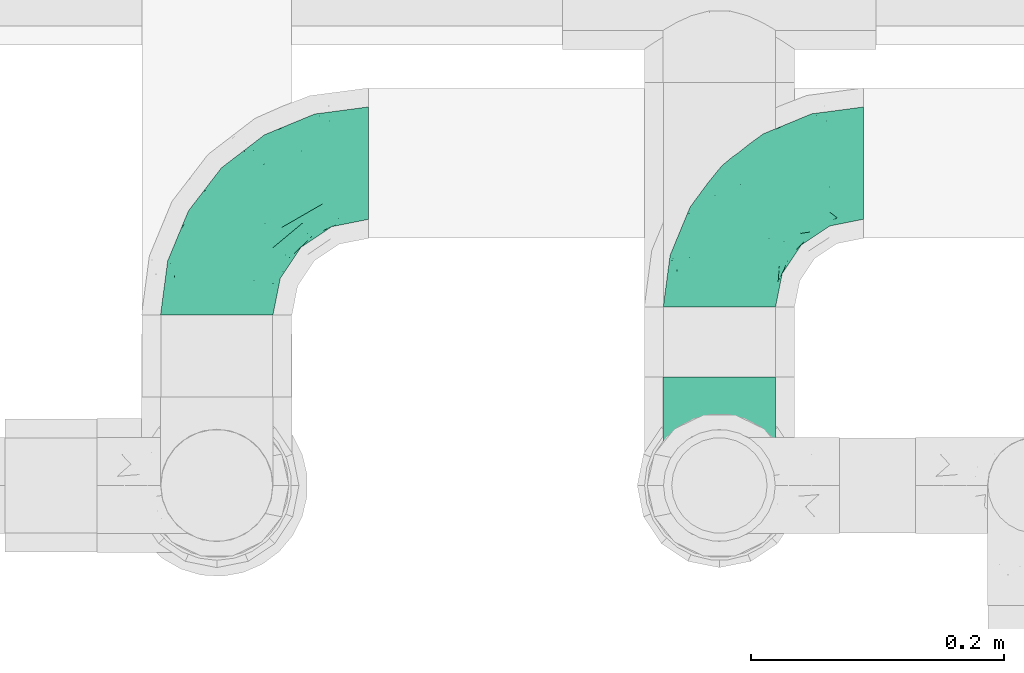
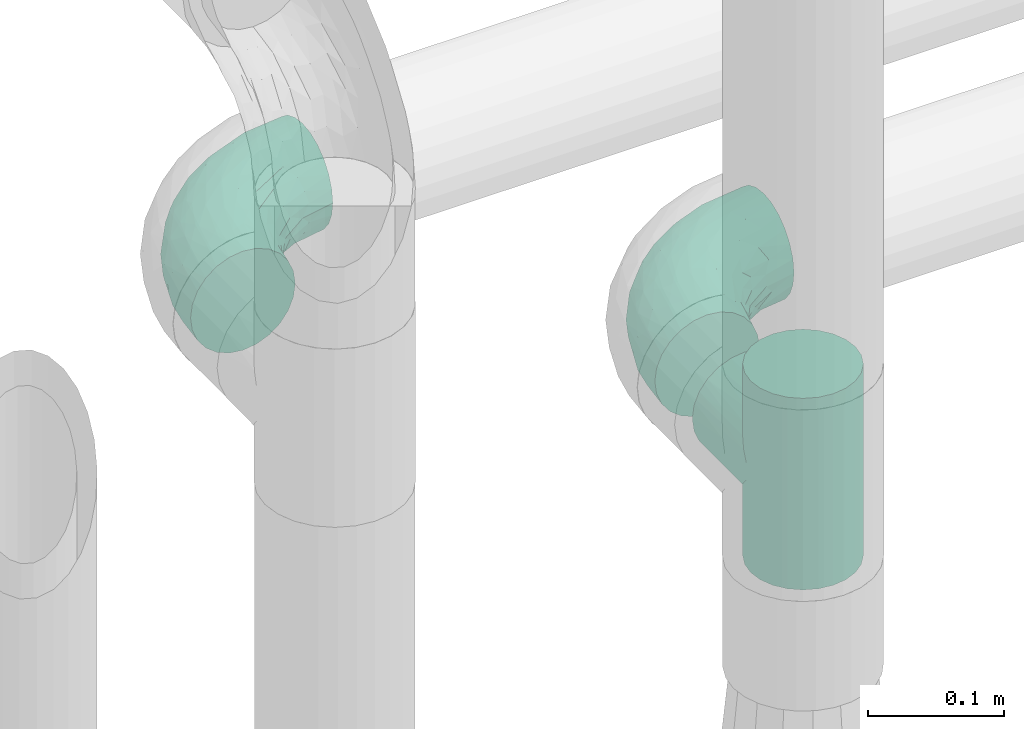
# One storey, part 705 of 824: 3 flow fittings.
"""IFC2X3 building model written with IfcOpenShell, lengths in millimetres."""

from ifc_helpers import new_model, entity, si_unit, converted_unit, derived_unit, direction, frame, origin, place, context, subcontext, project, spatial, faceted_brep, source, transform, mapped, material, type_object, type_shapes, element, save


model = new_model("IFC2X3")

# Units and contexts
model_context = context("Model", 3, precision=0.01, world=origin(), true_north=direction((6.12303176911189e-17, 1.0)))
body_context = subcontext(model_context, "Body", "Model", "MODEL_VIEW")
ifc_project = project(units=[si_unit("LENGTHUNIT", "METRE", prefix="MILLI"), si_unit("AREAUNIT", "SQUARE_METRE"), si_unit("VOLUMEUNIT", "CUBIC_METRE"), converted_unit("PLANEANGLEUNIT", "DEGREE", entity("IfcRatioMeasure", 0.0174532925199433), si_unit("PLANEANGLEUNIT", "RADIAN"), dimensions=[0, 0, 0, 0, 0, 0, 0]), si_unit("MASSUNIT", "GRAM", prefix="KILO"), derived_unit("MASSDENSITYUNIT", [(si_unit("MASSUNIT", "GRAM", prefix="KILO"), 1), (si_unit("LENGTHUNIT", "METRE"), -3)]), derived_unit("MOMENTOFINERTIAUNIT", [(si_unit("LENGTHUNIT", "METRE"), 4)]), si_unit("TIMEUNIT", "SECOND"), si_unit("FREQUENCYUNIT", "HERTZ"), si_unit("THERMODYNAMICTEMPERATUREUNIT", "DEGREE_CELSIUS"), derived_unit("THERMALTRANSMITTANCEUNIT", [(si_unit("MASSUNIT", "GRAM", prefix="KILO"), 1), (si_unit("THERMODYNAMICTEMPERATUREUNIT", "KELVIN"), -1), (si_unit("TIMEUNIT", "SECOND"), -3)]), derived_unit("VOLUMETRICFLOWRATEUNIT", [(si_unit("LENGTHUNIT", "METRE"), 3), (si_unit("TIMEUNIT", "SECOND"), -1)]), derived_unit("MASSFLOWRATEUNIT", [(si_unit("MASSUNIT", "GRAM", prefix="KILO"), 1), (si_unit("TIMEUNIT", "SECOND"), -1)]), derived_unit("ROTATIONALFREQUENCYUNIT", [(si_unit("TIMEUNIT", "SECOND"), -1)]), si_unit("ELECTRICCURRENTUNIT", "AMPERE"), si_unit("ELECTRICVOLTAGEUNIT", "VOLT"), si_unit("POWERUNIT", "WATT"), si_unit("FORCEUNIT", "NEWTON", prefix="KILO"), si_unit("ILLUMINANCEUNIT", "LUX"), si_unit("LUMINOUSFLUXUNIT", "LUMEN"), si_unit("LUMINOUSINTENSITYUNIT", "CANDELA"), derived_unit("USERDEFINED", [(si_unit("MASSUNIT", "GRAM", prefix="KILO"), -1), (si_unit("LENGTHUNIT", "METRE"), -2), (si_unit("TIMEUNIT", "SECOND"), 3), (si_unit("LUMINOUSFLUXUNIT", "LUMEN"), 1)]), derived_unit("LINEARVELOCITYUNIT", [(si_unit("LENGTHUNIT", "METRE"), 1), (si_unit("TIMEUNIT", "SECOND"), -1)]), si_unit("PRESSUREUNIT", "PASCAL"), derived_unit("USERDEFINED", [(si_unit("LENGTHUNIT", "METRE"), -2), (si_unit("MASSUNIT", "GRAM", prefix="KILO"), 1), (si_unit("TIMEUNIT", "SECOND"), -2)]), derived_unit("LINEARFORCEUNIT", [(si_unit("MASSUNIT", "GRAM", prefix="KILO"), 1), (si_unit("LENGTHUNIT", "METRE"), 1), (si_unit("TIMEUNIT", "SECOND"), -2), (si_unit("LENGTHUNIT", "METRE"), -1)]), derived_unit("PLANARFORCEUNIT", [(si_unit("MASSUNIT", "GRAM", prefix="KILO"), 1), (si_unit("LENGTHUNIT", "METRE"), 1), (si_unit("TIMEUNIT", "SECOND"), -2), (si_unit("LENGTHUNIT", "METRE"), -2)])], contexts=[model_context])

# Site, building, storey
site_placement = place(None, origin())
site = spatial("IfcSite", under=ifc_project, at=site_placement, CompositionType="ELEMENT")
building_placement = place(site_placement, origin())
building = spatial("IfcBuilding", under=site, at=building_placement, CompositionType="ELEMENT")
storey_placement = place(building_placement, frame((0.0, 0.0, 28200.0)))
storey = spatial("IfcBuildingStorey", under=building, at=storey_placement, CompositionType="ELEMENT", Elevation=28200.0)

# Flow fittings
ifc_material = material()
pipe_fitting_type_1 = type_object("IfcPipeFittingType", PredefinedType="NOTDEFINED", material=ifc_material)
shared_shape_1 = source(origin(), body_context, "Body", "Brep", [
    faceted_brep([(-120.0, 22.25, -38.54), (-120.0, 11.52, -42.98), (-120.0, 0.0, -44.5), (-120.0, -11.52, -42.98), (-120.0, -22.25, -38.54), (-120.0, -31.47, -31.47), (-120.0, -38.54, -22.25), (-120.0, -42.98, -11.52), (-120.0, -44.5, 0.0), (-120.0, -42.98, 11.52), (-120.0, -38.54, 22.25), (-120.0, -31.47, 31.47), (-120.0, -22.25, 38.54), (-120.0, -11.52, 42.98), (-120.0, 0.0, 44.5), (-120.0, 11.52, 42.98), (-120.0, 22.25, 38.54), (-120.0, 31.47, 31.47), (-120.0, 38.54, 22.25), (-120.0, 42.98, 11.52), (-120.0, 44.5, 0.0), (-120.0, 42.98, -11.52), (-120.0, 38.54, -22.25), (-120.0, 31.47, -31.47), (0.0, 120.0, -44.5), (-11.52, 120.0, -42.98), (-22.25, 120.0, -38.54), (-31.47, 120.0, -31.47), (-38.54, 120.0, -22.25), (-42.98, 120.0, -11.52), (-44.5, 120.0, 0.0), (-42.98, 120.0, 11.52), (-38.54, 120.0, 22.25), (-31.47, 120.0, 31.47), (-22.25, 120.0, 38.54), (-11.52, 120.0, 42.98), (0.0, 120.0, 44.5), (11.52, 120.0, 42.98), (22.25, 120.0, 38.54), (31.47, 120.0, 31.47), (38.54, 120.0, 22.25), (42.98, 120.0, 11.52), (44.5, 120.0, 0.0), (42.98, 120.0, -11.52), (38.54, 120.0, -22.25), (31.47, 120.0, -31.47), (22.25, 120.0, -38.54), (11.52, 120.0, -42.98), (-20.51, 85.66, 41.98), (-29.31, 93.55, 36.45), (-98.0, -41.6, 0.0), (-80.92, -37.22, 14.68), (-66.68, -9.63, 39.67), (-84.59, -24.55, 33.9), (-50.35, -12.87, 32.85), (-77.42, -38.89, 0.0), (-22.01, -9.62, 13.21), (-37.75, -22.46, 0.0), (-20.72, -9.39, 0.0), (-89.18, -33.47, 25.4), (12.87, 50.35, 32.85), (24.55, 84.59, 33.9), (9.63, 66.68, 39.67), (-49.55, -27.06, 11.21), (-28.67, -9.99, 21.67), (-52.01, -22.41, 23.47), (-95.53, -16.28, 40.49), (-86.01, -3.42, 43.77), (22.41, 52.01, 23.47), (9.05, 21.37, 13.44), (26.5, 49.37, 12.73), (33.47, 89.18, 25.4), (37.22, 80.92, 14.68), (16.28, 95.53, 40.49), (3.42, 86.01, 43.77), (-7.84, 52.6, 43.16), (-84.39, 31.88, 36.84), (-30.52, 34.28, 44.33), (-21.99, 28.55, 42.22), (-93.56, 38.23, 28.63), (-65.04, 31.74, 41.51), (-91.98, 19.0, 41.83), (-34.03, 70.24, 39.41), (-96.36, 44.0, 18.64), (-98.49, 46.74, 8.65), (-76.5, 56.97, 9.76), (-4.96, 4.47, 11.32), (-7.16, 6.18, 18.93), (-56.62, 75.93, 12.18), (-66.61, 66.61, 0.0), (-92.12, 7.25, 44.33), (-7.23, 92.66, 44.32), (30.68, 57.59, 0.0), (-44.45, 94.8, 18.75), (-36.39, 101.98, 28.14), (-46.83, 97.45, 9.69), (-38.03, 47.61, 43.21), (-24.7, 65.7, 43.29), (41.6, 98.0, 0.0), (-54.11, 72.8, 21.53), (-47.95, 9.75, 42.93), (-18.65, 18.65, 37.89), (-91.11, 50.25, 0.0), (-50.25, 91.11, 0.0), (-57.59, -30.68, 0.0), (-44.16, 67.2, 34.92), (-55.15, 62.16, 29.74), (-68.1, 47.21, 32.31), (-51.09, 51.09, 38.36), (-16.69, 62.62, 44.46), (-58.26, 18.84, 44.48), (-71.55, 55.71, 20.49), (-43.13, 80.04, 29.45), (-37.23, 0.88, 36.78), (-18.15, 10.22, 33.09), (5.51, 28.08, 26.74), (-3.68, 3.68, 0.0), (9.39, 20.72, 0.0), (-2.58, 27.98, 33.59), (-2.38, 41.22, 38.93), (-16.09, 4.55, 27.06), (38.89, 77.42, 0.0), (22.46, 37.75, 0.0), (-92.66, 7.23, -44.32), (-22.01, -9.62, -13.21), (-49.81, -26.66, -12.91), (-28.67, -9.99, -21.67), (-62.62, 16.69, -44.46), (-65.04, 31.74, -41.51), (-38.89, 47.26, -43.11), (-56.62, 75.93, -12.18), (-93.56, 38.23, -28.63), (-84.39, 31.88, -36.84), (16.28, 95.53, -40.49), (3.42, 86.01, -43.77), (-98.49, 46.74, -8.65), (-44.45, 94.8, -18.75), (-54.11, 72.8, -21.53), (-76.5, 56.97, -9.76), (24.55, 84.59, -33.9), (9.63, 66.68, -39.67), (-96.36, 44.0, -18.64), (-29.4, 93.16, -36.47), (-91.98, 19.0, -41.83), (-80.92, -37.22, -14.68), (-52.6, 7.84, -43.16), (-86.01, -3.42, -43.77), (-89.18, -33.47, -25.4), (-52.01, -22.41, -23.47), (-50.35, -12.87, -32.85), (-84.59, -24.55, -33.9), (-66.68, -9.63, -39.67), (-95.53, -16.28, -40.49), (-68.1, 47.21, -32.31), (-35.81, 11.1, -40.85), (-19.61, 28.53, -41.59), (-18.65, 18.65, -37.89), (-4.97, 4.47, -11.34), (9.05, 21.37, -13.44), (-34.28, 30.52, -44.33), (-9.75, 47.95, -42.93), (-2.58, 27.98, -33.59), (-18.15, 10.22, -33.09), (-46.83, 97.45, -9.69), (12.87, 50.35, -32.85), (26.8, 49.13, -11.4), (-7.34, 92.03, -44.33), (-21.02, 83.86, -42.03), (-44.6, 66.82, -34.8), (-55.46, 62.18, -29.47), (37.22, 80.92, -14.68), (33.47, 89.18, -25.4), (-34.39, 70.11, -39.28), (-25.04, 64.41, -43.37), (-18.84, 58.26, -44.48), (22.41, 52.01, -23.47), (-36.39, 101.98, -28.14), (-51.09, 51.09, -38.36), (-43.13, 80.04, -29.45), (-71.55, 55.71, -20.49), (-7.15, 6.2, -18.94), (5.51, 28.08, -26.74), (-37.23, 0.88, -36.78), (-2.38, 41.22, -38.93), (-16.09, 4.55, -27.06)], [[[0, 1, 2, 3, 4, 5, 6, 7, 8, 9, 10, 11, 12, 13, 14, 15, 16, 17, 18, 19, 20, 21, 22, 23]], [[24, 25, 26, 27, 28, 29, 30, 31, 32, 33, 34, 35, 36, 37, 38, 39, 40, 41, 42, 43, 44, 45, 46, 47]], [[48, 34, 49]], [[50, 51, 9]], [[52, 53, 54]], [[9, 51, 10]], [[55, 51, 50]], [[56, 57, 58]], [[51, 59, 10]], [[60, 61, 62]], [[63, 64, 65]], [[13, 12, 66]], [[67, 14, 13]], [[68, 69, 70]], [[71, 68, 72]], [[38, 73, 61]], [[74, 75, 62]], [[17, 16, 76]], [[77, 78, 75]], [[79, 18, 17]], [[80, 76, 81]], [[35, 34, 48]], [[49, 82, 48]], [[18, 83, 19]], [[16, 81, 76]], [[20, 19, 84]], [[85, 84, 83]], [[56, 86, 87]], [[85, 88, 89]], [[37, 36, 74]], [[90, 14, 67]], [[79, 17, 76]], [[63, 65, 51]], [[13, 66, 67]], [[61, 39, 38]], [[91, 74, 36]], [[70, 92, 72]], [[93, 94, 32]], [[95, 88, 93]], [[62, 73, 74]], [[82, 96, 97]], [[40, 72, 41]], [[72, 68, 70]], [[71, 72, 40]], [[34, 33, 49]], [[72, 98, 41]], [[99, 93, 88]], [[71, 39, 61]], [[78, 100, 101]], [[85, 89, 102]], [[53, 52, 66]], [[103, 95, 30]], [[12, 11, 53]], [[103, 89, 88]], [[104, 57, 63]], [[91, 48, 97]], [[93, 32, 31]], [[33, 32, 94]], [[16, 15, 81]], [[105, 106, 107]], [[76, 107, 79]], [[35, 91, 36]], [[80, 96, 108]], [[31, 95, 93]], [[65, 53, 59]], [[73, 38, 37]], [[75, 74, 109]], [[61, 60, 68]], [[11, 10, 59]], [[54, 53, 65]], [[100, 67, 52]], [[110, 81, 90]], [[15, 14, 90]], [[76, 80, 108]], [[107, 76, 108]], [[83, 79, 111]], [[94, 49, 33]], [[82, 105, 108]], [[84, 85, 102]], [[111, 88, 85]], [[99, 88, 111]], [[94, 93, 112]], [[48, 91, 35]], [[74, 91, 109]], [[69, 87, 86]], [[113, 54, 114]], [[64, 56, 87]], [[60, 115, 68]], [[116, 117, 86]], [[69, 68, 115]], [[79, 83, 18]], [[85, 83, 111]], [[81, 110, 80]], [[110, 77, 96]], [[110, 96, 80]], [[97, 96, 109]], [[107, 108, 105]], [[111, 79, 107]], [[77, 75, 109]], [[118, 119, 101]], [[96, 77, 109]], [[77, 110, 100]], [[67, 100, 110]], [[100, 52, 113]], [[60, 119, 118]], [[118, 120, 115]], [[64, 54, 65]], [[114, 120, 118]], [[118, 115, 60]], [[115, 120, 87]], [[74, 73, 37]], [[61, 73, 62]], [[53, 66, 12]], [[67, 66, 52]], [[110, 90, 67]], [[15, 90, 81]], [[105, 49, 112]], [[96, 82, 108]], [[119, 60, 62]], [[118, 101, 114]], [[62, 75, 119]], [[78, 119, 75]], [[49, 105, 82]], [[105, 112, 106]], [[99, 112, 93]], [[111, 107, 106]], [[113, 114, 101]], [[54, 120, 114]], [[100, 113, 101]], [[52, 54, 113]], [[20, 84, 102]], [[83, 84, 19]], [[111, 106, 99]], [[112, 99, 106]], [[100, 78, 77]], [[119, 78, 101]], [[39, 71, 40]], [[68, 71, 61]], [[65, 59, 51]], [[11, 59, 53]], [[30, 95, 31]], [[103, 88, 95]], [[9, 8, 50]], [[98, 72, 121]], [[98, 42, 41]], [[49, 94, 112]], [[56, 63, 57]], [[51, 55, 104]], [[92, 121, 72]], [[86, 58, 116]], [[54, 64, 120]], [[115, 87, 69]], [[120, 64, 87]], [[58, 86, 56]], [[86, 117, 69]], [[91, 97, 109]], [[122, 69, 117]], [[82, 97, 48]], [[63, 56, 64]], [[104, 63, 51]], [[69, 122, 70]], [[92, 70, 122]], [[123, 2, 1]], [[124, 125, 126]], [[127, 128, 129]], [[103, 130, 89]], [[23, 131, 132]], [[47, 133, 134]], [[102, 135, 20]], [[130, 136, 137]], [[102, 138, 135]], [[139, 140, 133]], [[22, 21, 141]], [[27, 26, 142]], [[46, 45, 139]], [[0, 143, 1]], [[6, 144, 7]], [[145, 146, 127]], [[144, 50, 7]], [[147, 148, 144]], [[144, 6, 147]], [[149, 150, 151]], [[4, 3, 152]], [[23, 22, 131]], [[132, 131, 153]], [[43, 42, 98]], [[125, 104, 144]], [[154, 155, 156]], [[146, 151, 152]], [[4, 150, 5]], [[123, 146, 2]], [[157, 158, 117]], [[130, 138, 89]], [[29, 28, 136]], [[159, 160, 155]], [[161, 162, 156]], [[89, 138, 102]], [[163, 30, 29]], [[164, 140, 139]], [[163, 136, 130]], [[23, 132, 0]], [[158, 165, 122]], [[25, 24, 166]], [[0, 132, 143]], [[4, 152, 150]], [[142, 26, 167]], [[3, 2, 146]], [[167, 26, 25]], [[133, 47, 46]], [[168, 153, 169]], [[146, 145, 151]], [[149, 126, 148]], [[44, 170, 171]], [[24, 47, 134]], [[170, 44, 43]], [[144, 148, 125]], [[170, 98, 121]], [[168, 142, 172]], [[129, 173, 174]], [[98, 170, 43]], [[147, 5, 150]], [[157, 58, 124]], [[92, 122, 165]], [[134, 166, 24]], [[175, 139, 171]], [[28, 27, 176]], [[29, 136, 163]], [[132, 128, 143]], [[45, 44, 171]], [[164, 139, 175]], [[160, 134, 140]], [[174, 173, 166]], [[141, 131, 22]], [[132, 153, 177]], [[128, 132, 177]], [[123, 143, 127]], [[172, 142, 167]], [[176, 142, 178]], [[130, 179, 138]], [[138, 179, 141]], [[176, 136, 28]], [[130, 137, 179]], [[174, 166, 134]], [[167, 25, 166]], [[143, 123, 1]], [[146, 123, 127]], [[150, 149, 148]], [[157, 124, 180]], [[181, 161, 164]], [[181, 158, 180]], [[124, 126, 180]], [[170, 165, 175]], [[141, 21, 135]], [[131, 141, 179]], [[131, 179, 153]], [[179, 137, 169]], [[129, 128, 177]], [[127, 143, 128]], [[129, 177, 172]], [[129, 174, 159]], [[159, 145, 127]], [[182, 154, 156]], [[129, 159, 127]], [[159, 174, 160]], [[134, 160, 174]], [[140, 164, 183]], [[162, 182, 156]], [[126, 149, 184]], [[181, 164, 175]], [[164, 161, 183]], [[158, 181, 175]], [[184, 162, 161]], [[146, 152, 3]], [[150, 152, 151]], [[139, 133, 46]], [[134, 133, 140]], [[184, 161, 181]], [[161, 156, 183]], [[155, 183, 156]], [[160, 140, 183]], [[184, 149, 162]], [[182, 162, 149]], [[149, 151, 182]], [[154, 151, 145]], [[151, 154, 182]], [[159, 154, 145]], [[159, 155, 154]], [[183, 155, 160]], [[141, 135, 138]], [[20, 135, 21]], [[136, 178, 137]], [[169, 178, 168]], [[172, 167, 173]], [[168, 172, 177]], [[153, 168, 177]], [[142, 168, 178]], [[179, 169, 153]], [[137, 178, 169]], [[5, 147, 6]], [[148, 147, 150]], [[175, 171, 170]], [[45, 171, 139]], [[130, 103, 163]], [[30, 163, 103]], [[50, 144, 55]], [[50, 8, 7]], [[142, 176, 27]], [[136, 176, 178]], [[126, 125, 148]], [[104, 55, 144]], [[170, 121, 92]], [[58, 57, 124]], [[180, 126, 184]], [[181, 180, 184]], [[180, 158, 157]], [[158, 122, 117]], [[58, 157, 116]], [[172, 173, 129]], [[116, 157, 117]], [[166, 173, 167]], [[124, 57, 125]], [[104, 125, 57]], [[175, 165, 158]], [[92, 165, 170]]]),
])
type_shapes(pipe_fitting_type_1, [shared_shape_1])
flow_fitting_1_placement = place(storey_placement, frame((57050.07, 17755.1, 2300.0), z_axis=(0.0, 0.0, 1.0), x_axis=(-1.0, 0.0, 0.0)))
element("IfcFlowFitting", 1, at=flow_fitting_1_placement, inside=storey, type_object=pipe_fitting_type_1, material=ifc_material, context=body_context, shape_type="MappedRepresentation", body=[
    mapped(shared_shape_1, transform((0.0, 0.0, 0.0), scale=1.0)),
])
pipe_fitting_type_2 = type_object("IfcPipeFittingType", PredefinedType="NOTDEFINED", material=ifc_material)
shared_shape_2 = source(origin(), body_context, "Body", "Brep", [
    faceted_brep([(-114.0, 22.22, -38.49), (-114.0, 11.5, -42.94), (-114.0, 0.0, -44.45), (-114.0, -11.5, -42.94), (-114.0, -22.23, -38.49), (-114.0, -31.43, -31.43), (-114.0, -38.49, -22.23), (-114.0, -42.94, -11.5), (-114.0, -44.45, 0.0), (-114.0, -42.94, 11.5), (-114.0, -38.49, 22.22), (-114.0, -31.43, 31.43), (-114.0, -22.23, 38.49), (-114.0, -11.5, 42.94), (-114.0, 0.0, 44.45), (-114.0, 11.5, 42.94), (-114.0, 22.22, 38.49), (-114.0, 31.43, 31.43), (-114.0, 38.49, 22.22), (-114.0, 42.94, 11.5), (-114.0, 44.45, 0.0), (-114.0, 42.94, -11.5), (-114.0, 38.49, -22.23), (-114.0, 31.43, -31.43), (0.0, 114.0, -44.45), (-11.5, 114.0, -42.94), (-22.22, 114.0, -38.49), (-31.43, 114.0, -31.43), (-38.49, 114.0, -22.23), (-42.94, 114.0, -11.5), (-44.45, 114.0, 0.0), (-42.94, 114.0, 11.5), (-38.49, 114.0, 22.22), (-31.43, 114.0, 31.43), (-22.22, 114.0, 38.49), (-11.5, 114.0, 42.94), (0.0, 114.0, 44.45), (11.5, 114.0, 42.94), (22.23, 114.0, 38.49), (31.43, 114.0, 31.43), (38.49, 114.0, 22.22), (42.94, 114.0, 11.5), (44.45, 114.0, 0.0), (42.94, 114.0, -11.5), (38.49, 114.0, -22.23), (31.43, 114.0, -31.43), (22.23, 114.0, -38.49), (11.5, 114.0, -42.94), (-24.5, -15.82, 8.24), (-7.18, -2.06, 7.97), (-13.53, -4.79, 15.72), (-92.03, -41.56, 0.0), (-77.08, -37.56, 14.57), (23.74, 74.96, 33.55), (-72.99, -39.05, 0.0), (-84.56, -15.6, 40.23), (-47.88, -6.37, 37.83), (-59.8, 2.77, 43.37), (-84.46, -33.54, 25.41), (16.69, 49.28, 31.02), (6.37, 47.88, 37.83), (3.35, 25.47, 29.77), (-47.43, 81.55, 19.51), (-74.96, -23.74, 33.55), (-46.77, -27.89, 11.23), (-53.88, -31.14, 0.0), (-87.05, 38.52, 28.81), (-63.44, 55.78, 24.79), (-93.24, 43.37, 18.58), (-16.67, 16.67, 37.64), (-25.47, -3.35, 29.77), (-17.2, 97.7, 41.53), (-7.42, 85.54, 44.3), (-67.09, 46.29, 31.23), (-18.08, 42.1, 44.06), (-32.93, 14.9, 42.17), (-11.54, 34.94, 41.69), (-95.7, 27.79, 36.14), (-88.55, -4.92, 43.79), (-2.77, 59.8, 43.37), (-87.65, 48.44, 9.87), (-81.01, 8.37, 44.32), (-37.63, 90.26, 28.6), (-51.29, 61.56, 30.59), (-29.32, 87.72, 36.52), (23.49, 49.5, 23.28), (8.19, 20.11, 19.18), (-70.06, 58.9, 9.01), (-87.38, 49.74, 0.0), (-88.15, 18.57, 41.8), (-7.96, 6.22, 24.33), (33.54, 84.46, 25.41), (37.56, 77.08, 14.57), (-58.37, 34.98, 40.92), (-62.38, 23.02, 43.45), (24.15, 39.93, 12.16), (31.14, 53.88, 0.0), (-58.13, 14.61, 44.45), (-37.17, 26.09, 44.37), (4.92, 88.55, 43.79), (-34.77, -23.22, 0.0), (-49.5, -23.49, 23.28), (41.56, 92.03, 0.0), (-57.83, 66.03, 19.12), (-71.84, 54.46, 17.06), (-46.46, 94.23, 8.51), (-49.74, 87.38, 0.0), (-38.96, 59.98, 38.88), (-55.29, 46.95, 36.83), (-64.82, 64.82, 0.0), (-55.88, 73.75, 10.01), (15.6, 84.56, 40.23), (-21.6, 76.38, 42.11), (-49.04, -15.53, 31.95), (-19.97, 55.59, 44.33), (-73.61, 33.95, 37.2), (-31.05, 58.14, 42.19), (-41.3, 41.3, 43.02), (-27.36, -11.22, 22.61), (9.28, 15.84, 8.73), (23.22, 34.77, 0.0), (39.05, 72.99, 0.0), (-1.96, 1.96, 0.0), (10.63, 18.37, 0.0), (-18.37, -10.63, 0.0), (-97.7, 17.2, -41.53), (9.28, 15.84, -8.73), (-13.53, -4.79, -15.72), (8.19, 20.11, -19.18), (-85.54, 7.42, -44.3), (-8.37, 81.01, -44.32), (-90.26, 37.63, -28.6), (-87.72, 29.32, -36.52), (-27.79, 95.7, -36.14), (-38.52, 87.05, -28.81), (-94.23, 46.46, -8.51), (-84.56, -15.6, -40.23), (-73.75, 55.88, -10.01), (-10.19, -4.86, -7.51), (-76.38, 21.6, -42.11), (-59.98, 38.96, -38.88), (-49.28, -16.69, -31.02), (-47.88, -6.37, -37.83), (-25.47, -3.35, -29.77), (-34.98, 58.37, -40.92), (-46.95, 55.29, -36.83), (-77.08, -37.56, -14.57), (-18.57, 88.15, -41.8), (-23.02, 62.38, -43.45), (-55.78, 63.44, -24.79), (-43.37, 93.24, -18.58), (-84.46, -33.54, -25.41), (-33.95, 73.61, -37.2), (-46.29, 67.09, -31.23), (-74.96, -23.74, -33.55), (-48.44, 87.65, -9.87), (-45.44, -27.06, -11.87), (-88.55, -4.92, -43.79), (-49.5, -23.49, -23.28), (-14.61, 58.13, -44.45), (-26.09, 37.17, -44.37), (15.6, 84.56, -40.23), (6.37, 47.88, -37.83), (-2.77, 59.8, -43.37), (-81.55, 47.43, -19.51), (33.54, 84.46, -25.41), (23.49, 49.5, -23.28), (23.74, 74.96, -33.55), (-42.1, 18.08, -44.06), (-14.9, 32.93, -42.17), (-34.94, 11.54, -41.69), (-61.56, 51.29, -30.59), (-27.36, -11.22, -22.61), (37.56, 77.08, -14.57), (4.92, 88.55, -43.79), (-59.8, 2.77, -43.37), (-66.03, 57.83, -19.12), (-54.46, 71.84, -17.06), (-55.59, 19.97, -44.33), (-58.9, 70.06, -9.01), (24.15, 39.93, -12.16), (15.53, 49.04, -31.95), (-58.14, 31.05, -42.19), (-41.3, 41.3, -43.02), (-16.67, 16.67, -37.64), (3.35, 25.47, -29.77), (-7.96, 6.22, -24.33), (-26.36, -16.33, -11.05)], [[[0, 1, 2, 3, 4, 5, 6, 7, 8, 9, 10, 11, 12, 13, 14, 15, 16, 17, 18, 19, 20, 21, 22, 23]], [[24, 25, 26, 27, 28, 29, 30, 31, 32, 33, 34, 35, 36, 37, 38, 39, 40, 41, 42, 43, 44, 45, 46, 47]], [[48, 49, 50]], [[51, 52, 9]], [[53, 39, 38]], [[9, 52, 10]], [[54, 52, 51]], [[55, 56, 57]], [[11, 10, 58]], [[59, 60, 61]], [[32, 31, 62]], [[63, 12, 11]], [[63, 55, 12]], [[64, 52, 65]], [[66, 67, 68]], [[69, 56, 70]], [[35, 71, 72]], [[67, 66, 73]], [[74, 75, 76]], [[16, 77, 17]], [[13, 78, 14]], [[76, 79, 74]], [[68, 80, 19]], [[18, 17, 66]], [[14, 78, 81]], [[20, 19, 80]], [[82, 83, 84]], [[85, 61, 86]], [[87, 88, 80]], [[18, 68, 19]], [[15, 89, 16]], [[14, 81, 15]], [[70, 90, 61]], [[17, 77, 66]], [[91, 85, 92]], [[93, 89, 94]], [[95, 96, 92]], [[84, 71, 34]], [[94, 97, 98]], [[37, 36, 99]], [[40, 39, 91]], [[40, 92, 41]], [[65, 100, 64]], [[91, 92, 40]], [[58, 101, 63]], [[92, 102, 41]], [[92, 85, 95]], [[67, 103, 104]], [[34, 33, 84]], [[105, 62, 31]], [[52, 58, 10]], [[106, 105, 30]], [[93, 107, 108]], [[106, 109, 110]], [[53, 111, 60]], [[84, 112, 71]], [[84, 107, 112]], [[33, 82, 84]], [[12, 55, 13]], [[113, 56, 63]], [[111, 38, 37]], [[34, 71, 35]], [[36, 35, 72]], [[112, 114, 72]], [[110, 105, 106]], [[111, 53, 38]], [[115, 108, 73]], [[89, 15, 81]], [[104, 87, 80]], [[110, 87, 103]], [[33, 32, 82]], [[116, 107, 117]], [[112, 116, 114]], [[99, 72, 79]], [[56, 55, 63]], [[78, 55, 57]], [[101, 118, 113]], [[56, 69, 75]], [[99, 111, 37]], [[79, 76, 60]], [[79, 60, 111]], [[60, 69, 61]], [[101, 58, 52]], [[63, 11, 58]], [[39, 53, 91]], [[85, 91, 53]], [[94, 89, 81]], [[77, 89, 115]], [[84, 83, 107]], [[93, 108, 115]], [[98, 114, 117]], [[79, 72, 114]], [[98, 117, 94]], [[98, 57, 75]], [[32, 62, 82]], [[83, 82, 62]], [[70, 113, 118]], [[61, 85, 59]], [[48, 64, 100]], [[95, 119, 120]], [[69, 70, 61]], [[70, 118, 90]], [[72, 99, 36]], [[111, 99, 79]], [[55, 78, 13]], [[81, 78, 57]], [[94, 81, 97]], [[93, 94, 117]], [[66, 68, 18]], [[80, 68, 104]], [[103, 87, 104]], [[80, 88, 20]], [[50, 49, 119]], [[95, 85, 86]], [[119, 95, 86]], [[121, 92, 96]], [[50, 119, 86]], [[119, 122, 123, 120]], [[110, 109, 87]], [[88, 87, 109]], [[62, 105, 110]], [[30, 105, 31]], [[81, 57, 97]], [[57, 98, 97]], [[107, 93, 117]], [[89, 93, 115]], [[107, 83, 108]], [[73, 108, 83]], [[67, 73, 83]], [[115, 73, 66]], [[103, 83, 62]], [[67, 104, 68]], [[83, 103, 67]], [[110, 103, 62]], [[89, 77, 16]], [[66, 77, 115]], [[56, 75, 57]], [[76, 75, 69]], [[60, 76, 69]], [[79, 114, 74]], [[114, 98, 74]], [[75, 74, 98]], [[9, 8, 51]], [[102, 92, 121]], [[102, 42, 41]], [[72, 71, 112]], [[52, 54, 65]], [[64, 48, 118]], [[101, 52, 64]], [[124, 122, 49]], [[118, 48, 50]], [[49, 48, 124]], [[119, 49, 122]], [[48, 100, 124]], [[114, 116, 117]], [[112, 107, 116]], [[101, 113, 63]], [[70, 56, 113]], [[64, 118, 101]], [[90, 50, 86]], [[50, 90, 118]], [[61, 90, 86]], [[85, 53, 59]], [[60, 59, 53]], [[95, 120, 96]], [[125, 1, 0]], [[126, 127, 128]], [[2, 1, 129]], [[24, 130, 25]], [[131, 132, 23]], [[27, 133, 134]], [[88, 135, 20]], [[136, 4, 3]], [[88, 109, 137]], [[138, 122, 124]], [[139, 132, 140]], [[141, 142, 143]], [[144, 140, 145]], [[125, 132, 139]], [[6, 146, 7]], [[144, 147, 148]], [[146, 51, 7]], [[134, 149, 150]], [[146, 6, 151]], [[152, 145, 153]], [[154, 4, 136]], [[154, 136, 142]], [[150, 155, 29]], [[43, 42, 102]], [[65, 146, 156]], [[0, 23, 132]], [[157, 3, 2]], [[146, 151, 158]], [[148, 159, 160]], [[161, 162, 163]], [[135, 164, 21]], [[165, 166, 167]], [[168, 169, 170]], [[147, 25, 130]], [[171, 132, 131]], [[155, 30, 29]], [[172, 141, 143]], [[134, 28, 27]], [[149, 134, 153]], [[173, 165, 44]], [[26, 25, 147]], [[22, 21, 164]], [[24, 174, 130]], [[133, 27, 26]], [[170, 175, 168]], [[24, 47, 174]], [[45, 167, 46]], [[28, 150, 29]], [[1, 125, 129]], [[156, 100, 65]], [[165, 45, 44]], [[161, 46, 167]], [[173, 44, 43]], [[6, 5, 151]], [[173, 102, 121]], [[137, 135, 88]], [[46, 161, 47]], [[102, 173, 43]], [[149, 176, 177]], [[172, 158, 141]], [[139, 178, 129]], [[154, 5, 4]], [[156, 146, 158]], [[106, 155, 179]], [[173, 96, 180]], [[181, 162, 167]], [[177, 179, 155]], [[137, 179, 176]], [[23, 22, 131]], [[182, 140, 183]], [[139, 182, 178]], [[157, 129, 175]], [[157, 136, 3]], [[175, 170, 142]], [[175, 142, 136]], [[142, 184, 143]], [[162, 161, 167]], [[174, 161, 163]], [[181, 166, 185]], [[162, 184, 169]], [[5, 154, 151]], [[158, 151, 154]], [[166, 165, 173]], [[167, 45, 165]], [[148, 147, 130]], [[133, 147, 152]], [[132, 171, 140]], [[144, 145, 152]], [[160, 178, 183]], [[175, 129, 178]], [[160, 183, 148]], [[160, 163, 169]], [[22, 164, 131]], [[171, 131, 164]], [[162, 185, 184]], [[186, 127, 172]], [[185, 128, 186]], [[156, 187, 100]], [[185, 166, 128]], [[143, 184, 185]], [[129, 157, 2]], [[136, 157, 175]], [[161, 174, 47]], [[130, 174, 163]], [[148, 130, 159]], [[144, 148, 183]], [[134, 150, 28]], [[155, 150, 177]], [[176, 179, 177]], [[155, 106, 30]], [[166, 180, 128]], [[128, 180, 126]], [[173, 180, 166]], [[126, 120, 123, 122]], [[120, 126, 180]], [[122, 138, 126]], [[137, 109, 179]], [[106, 179, 109]], [[164, 135, 137]], [[20, 135, 21]], [[130, 163, 159]], [[163, 160, 159]], [[140, 144, 183]], [[147, 144, 152]], [[140, 171, 145]], [[153, 145, 171]], [[149, 153, 171]], [[152, 153, 134]], [[176, 171, 164]], [[149, 177, 150]], [[171, 176, 149]], [[137, 176, 164]], [[147, 133, 26]], [[134, 133, 152]], [[162, 169, 163]], [[170, 169, 184]], [[142, 170, 184]], [[175, 178, 168]], [[178, 160, 168]], [[169, 168, 160]], [[51, 146, 54]], [[51, 8, 7]], [[132, 125, 0]], [[129, 125, 139]], [[156, 158, 172]], [[65, 54, 146]], [[178, 182, 183]], [[139, 140, 182]], [[158, 154, 141]], [[142, 141, 154]], [[186, 172, 143]], [[172, 127, 187]], [[185, 186, 143]], [[127, 186, 128]], [[187, 127, 138]], [[124, 100, 187]], [[126, 138, 127]], [[187, 138, 124]], [[172, 187, 156]], [[166, 181, 167]], [[185, 162, 181]], [[96, 173, 121]], [[96, 120, 180]]]),
])
type_shapes(pipe_fitting_type_2, [shared_shape_2])
flow_fitting_2_placement = place(storey_placement, frame((57447.89, 17755.1, 2100.0), z_axis=(0.0, 0.0, 1.0), x_axis=(-1.0, 0.0, 0.0)))
element("IfcFlowFitting", 2, at=flow_fitting_2_placement, inside=storey, type_object=pipe_fitting_type_2, material=ifc_material, context=body_context, shape_type="MappedRepresentation", body=[
    mapped(shared_shape_2, transform((0.0, 0.0, 0.0), scale=1.0)),
])
pipe_fitting_type_3 = type_object("IfcPipeFittingType", PredefinedType="NOTDEFINED", material=ifc_material)
shared_shape_3 = source(origin(), body_context, "Body", "Brep", [
    faceted_brep([(-86.0, 22.22, -38.49), (-86.0, 11.5, -42.94), (-86.0, 0.0, -44.45), (-86.0, -11.5, -42.94), (-86.0, -22.23, -38.49), (-86.0, -26.83, -34.96), (-86.0, -31.43, -31.43), (-86.0, -34.96, -26.83), (-86.0, -38.49, -22.23), (-86.0, -40.72, -16.86), (-86.0, -42.94, -11.5), (-86.0, -44.45, 0.0), (-86.0, -42.94, 11.5), (-86.0, -40.72, 16.86), (-86.0, -38.49, 22.22), (-86.0, -34.96, 26.83), (-86.0, -31.43, 31.43), (-86.0, -26.83, 34.96), (-86.0, -22.23, 38.49), (-86.0, -11.5, 42.94), (-86.0, 0.0, 44.45), (-86.0, 11.5, 42.94), (-86.0, 22.22, 38.49), (-86.0, 31.43, 31.43), (-86.0, 38.49, 22.22), (-86.0, 42.94, 11.5), (-86.0, 44.45, 0.0), (-86.0, 42.94, -11.5), (-86.0, 38.49, -22.23), (-86.0, 31.43, -31.43), (86.0, 0.0, -44.45), (86.0, 11.5, -42.94), (86.0, 22.22, -38.49), (86.0, 31.43, -31.43), (86.0, 38.49, -22.23), (86.0, 42.94, -11.5), (86.0, 44.45, 0.0), (86.0, 42.94, 11.5), (86.0, 38.49, 22.22), (86.0, 31.43, 31.43), (86.0, 22.22, 38.49), (86.0, 11.5, 42.94), (86.0, 0.0, 44.45), (86.0, -11.5, 42.94), (86.0, -22.23, 38.49), (86.0, -26.83, 34.96), (86.0, -31.43, 31.43), (86.0, -34.96, 26.83), (86.0, -38.49, 22.22), (86.0, -40.72, 16.86), (86.0, -42.94, 11.5), (86.0, -44.45, 0.0), (86.0, -42.94, -11.5), (86.0, -40.72, -16.86), (86.0, -38.49, -22.23), (86.0, -34.96, -26.83), (86.0, -31.43, -31.43), (86.0, -26.83, -34.96), (86.0, -22.23, -38.49), (86.0, -11.5, -42.94), (43.21, -43.21, 10.43), (44.45, -44.45, 0.0), (-43.21, -43.21, 10.43), (-44.45, -44.45, 0.0), (41.49, -41.49, 15.14), (39.77, -39.77, 19.85), (21.97, -21.97, 38.64), (34.75, -34.75, 27.71), (28.69, -28.69, 33.95), (-41.49, -41.49, 15.14), (-39.77, -39.77, 19.85), (-21.97, -21.97, 38.64), (-34.75, -34.75, 27.71), (-28.69, -28.69, 33.95), (-14.84, -14.84, 41.9), (7.47, -7.47, 43.82), (14.84, -14.84, 41.9), (0.0, 0.0, 44.45), (-7.47, -7.47, 43.82), (7.47, -7.47, -43.82), (0.0, 0.0, -44.45), (14.84, -14.84, -41.9), (-28.69, -28.69, -33.95), (-7.47, -7.47, -43.82), (-41.49, -41.49, -15.14), (-43.21, -43.21, -10.43), (-34.75, -34.75, -27.71), (-14.84, -14.84, -41.9), (21.97, -21.97, -38.64), (28.69, -28.69, -33.95), (-39.77, -39.77, -19.85), (34.75, -34.75, -27.71), (43.21, -43.21, -10.43), (41.49, -41.49, -15.14), (39.77, -39.77, -19.85), (-21.97, -21.97, -38.64), (31.43, -86.0, -31.43), (38.49, -86.0, -22.23), (42.94, -86.0, -11.5), (44.45, -86.0, 0.0), (42.94, -86.0, 11.5), (38.49, -86.0, 22.22), (31.43, -86.0, 31.43), (22.23, -86.0, 38.49), (11.5, -86.0, 42.94), (0.0, -86.0, 44.45), (-11.5, -86.0, 42.94), (-22.22, -86.0, 38.49), (-31.43, -86.0, 31.43), (-38.49, -86.0, 22.22), (-42.94, -86.0, 11.5), (-44.45, -86.0, 0.0), (-42.94, -86.0, -11.5), (-38.49, -86.0, -22.23), (-31.43, -86.0, -31.43), (-22.22, -86.0, -38.49), (-11.5, -86.0, -42.94), (0.0, -86.0, -44.45), (11.5, -86.0, -42.94), (22.23, -86.0, -38.49)], [[[0, 1, 2, 3, 4, 5, 6, 7, 8, 9, 10, 11, 12, 13, 14, 15, 16, 17, 18, 19, 20, 21, 22, 23, 24, 25, 26, 27, 28, 29]], [[30, 31, 32, 33, 34, 35, 36, 37, 38, 39, 40, 41, 42, 43, 44, 45, 46, 47, 48, 49, 50, 51, 52, 53, 54, 55, 56, 57, 58, 59]], [[51, 50, 60]], [[60, 61, 51]], [[62, 11, 63]], [[50, 49, 64]], [[49, 48, 65]], [[44, 66, 45]], [[46, 67, 48, 47]], [[67, 46, 68]], [[48, 67, 65]], [[68, 46, 45]], [[12, 69, 13]], [[70, 13, 69]], [[11, 62, 12]], [[12, 62, 69]], [[71, 18, 17]], [[72, 73, 16]], [[72, 16, 15, 14]], [[16, 73, 17]], [[71, 74, 18]], [[72, 14, 70]], [[49, 65, 64]], [[45, 66, 68]], [[43, 42, 75]], [[50, 64, 60]], [[66, 44, 76]], [[75, 76, 43]], [[75, 42, 77]], [[78, 77, 20]], [[76, 44, 43]], [[24, 23, 39, 38]], [[25, 24, 38, 37]], [[22, 21, 41, 40]], [[23, 22, 40, 39]], [[41, 21, 20, 77, 42]], [[26, 25, 37, 36]], [[70, 14, 13]], [[78, 19, 74]], [[19, 78, 20]], [[19, 18, 74]], [[71, 17, 73]], [[29, 28, 34, 33]], [[27, 35, 34, 28]], [[26, 36, 35, 27]], [[0, 29, 33, 32]], [[30, 59, 79]], [[31, 30, 80, 2, 1]], [[79, 59, 81]], [[82, 6, 5]], [[32, 31, 1, 0]], [[59, 58, 81]], [[30, 79, 80]], [[80, 83, 2]], [[10, 84, 85]], [[86, 8, 7, 6]], [[83, 87, 3]], [[2, 83, 3]], [[87, 4, 3]], [[88, 57, 89]], [[57, 56, 89]], [[9, 90, 84]], [[88, 58, 57]], [[91, 89, 56]], [[55, 54, 91, 56]], [[58, 88, 81]], [[52, 92, 93]], [[92, 52, 51]], [[94, 53, 93]], [[61, 92, 51]], [[85, 63, 11]], [[54, 94, 91]], [[82, 5, 95]], [[52, 93, 53]], [[5, 4, 95]], [[6, 82, 86]], [[94, 54, 53]], [[95, 4, 87]], [[10, 9, 84]], [[90, 9, 8]], [[10, 85, 11]], [[90, 8, 86]], [[96, 97, 98, 99, 100, 101, 102, 103, 104, 105, 106, 107, 108, 109, 110, 111, 112, 113, 114, 115, 116, 117, 118, 119]], [[62, 63, 111]], [[110, 62, 111]], [[108, 107, 73]], [[72, 109, 108]], [[70, 110, 109]], [[74, 107, 106]], [[110, 70, 69, 62]], [[73, 72, 108]], [[70, 109, 72]], [[74, 71, 107]], [[105, 77, 78]], [[74, 106, 78]], [[73, 107, 71]], [[78, 106, 105]], [[75, 105, 104]], [[103, 76, 104]], [[101, 100, 65]], [[67, 102, 101]], [[68, 103, 102]], [[60, 100, 99]], [[68, 66, 103]], [[76, 75, 104]], [[66, 76, 103]], [[61, 60, 99]], [[65, 67, 101]], [[100, 60, 64, 65]], [[68, 102, 67]], [[105, 75, 77]], [[61, 99, 92]], [[98, 92, 99]], [[96, 119, 89]], [[94, 98, 97]], [[96, 91, 97]], [[81, 119, 118]], [[98, 94, 93, 92]], [[89, 91, 96]], [[94, 97, 91]], [[81, 88, 119]], [[117, 80, 79]], [[81, 118, 79]], [[89, 119, 88]], [[79, 118, 117]], [[83, 117, 116]], [[115, 87, 116]], [[113, 112, 90]], [[86, 114, 113]], [[82, 115, 114]], [[85, 112, 111]], [[82, 95, 115]], [[87, 83, 116]], [[95, 87, 115]], [[63, 85, 111]], [[90, 86, 113]], [[112, 85, 84, 90]], [[82, 114, 86]], [[117, 83, 80]]]),
])
type_shapes(pipe_fitting_type_3, [shared_shape_3])
flow_fitting_3_placement = place(storey_placement, frame((57447.89, 17500.0, 2100.0), z_axis=(1.0, 0.0, 0.0), x_axis=(0.0, 0.0, 1.0)))
element("IfcFlowFitting", 3, at=flow_fitting_3_placement, inside=storey, type_object=pipe_fitting_type_3, material=ifc_material, context=body_context, shape_type="MappedRepresentation", body=[
    mapped(shared_shape_3, transform((0.0, 0.0, 0.0), scale=1.0)),
])

save(model, "model.ifc")
